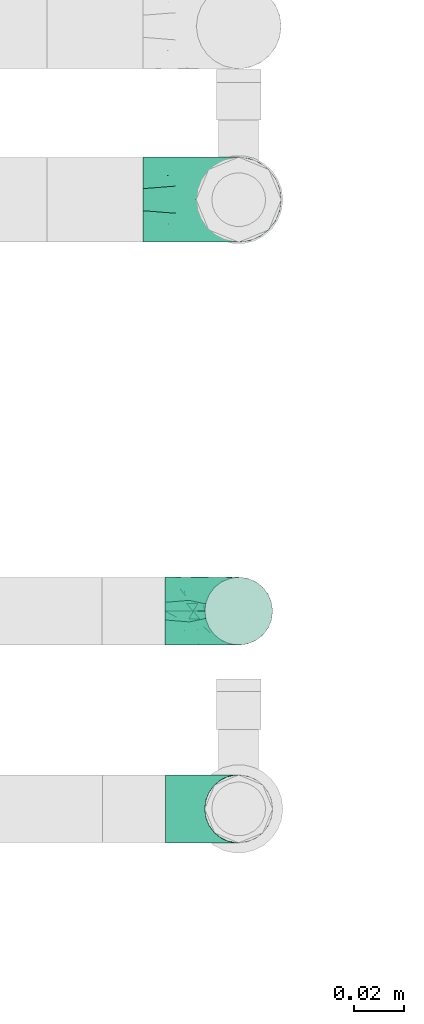
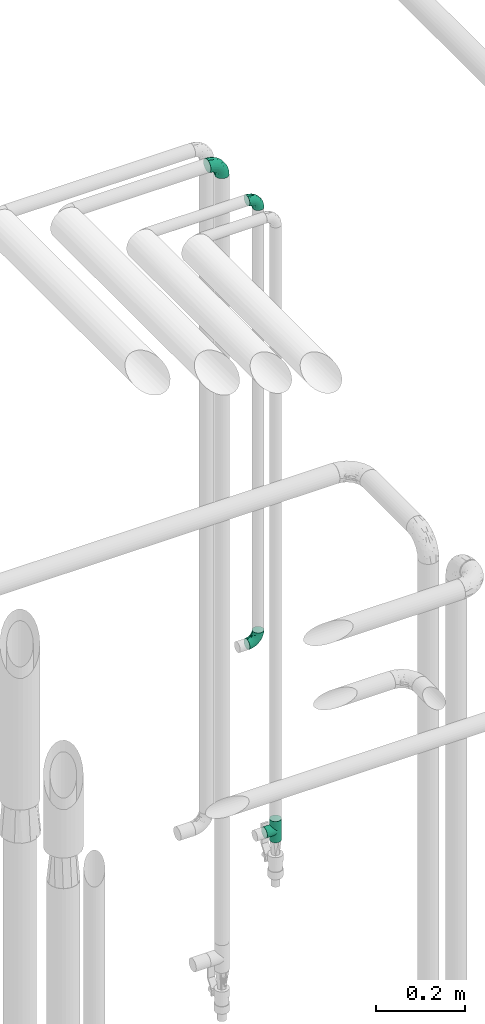
# One storey, part 747 of 827: 4 flow fittings.
"""IFC2X3 building model written with IfcOpenShell, lengths in millimetres."""

from ifc_helpers import new_model, entity, si_unit, converted_unit, derived_unit, direction, frame, origin, place, context, subcontext, project, spatial, faceted_brep, source, transform, mapped, material, type_object, type_shapes, element, save


model = new_model("IFC2X3")

# Units and contexts
model_context = context("Model", 3, precision=0.01, world=origin(), true_north=direction((6.12303176911189e-17, 1.0)))
body_context = subcontext(model_context, "Body", "Model", "MODEL_VIEW")
ifc_project = project(units=[si_unit("LENGTHUNIT", "METRE", prefix="MILLI"), si_unit("AREAUNIT", "SQUARE_METRE"), si_unit("VOLUMEUNIT", "CUBIC_METRE"), converted_unit("PLANEANGLEUNIT", "DEGREE", entity("IfcRatioMeasure", 0.0174532925199433), si_unit("PLANEANGLEUNIT", "RADIAN"), dimensions=[0, 0, 0, 0, 0, 0, 0]), si_unit("MASSUNIT", "GRAM", prefix="KILO"), derived_unit("MASSDENSITYUNIT", [(si_unit("MASSUNIT", "GRAM", prefix="KILO"), 1), (si_unit("LENGTHUNIT", "METRE"), -3)]), derived_unit("MOMENTOFINERTIAUNIT", [(si_unit("LENGTHUNIT", "METRE"), 4)]), si_unit("TIMEUNIT", "SECOND"), si_unit("FREQUENCYUNIT", "HERTZ"), si_unit("THERMODYNAMICTEMPERATUREUNIT", "DEGREE_CELSIUS"), derived_unit("THERMALTRANSMITTANCEUNIT", [(si_unit("MASSUNIT", "GRAM", prefix="KILO"), 1), (si_unit("THERMODYNAMICTEMPERATUREUNIT", "KELVIN"), -1), (si_unit("TIMEUNIT", "SECOND"), -3)]), derived_unit("VOLUMETRICFLOWRATEUNIT", [(si_unit("LENGTHUNIT", "METRE"), 3), (si_unit("TIMEUNIT", "SECOND"), -1)]), derived_unit("MASSFLOWRATEUNIT", [(si_unit("MASSUNIT", "GRAM", prefix="KILO"), 1), (si_unit("TIMEUNIT", "SECOND"), -1)]), derived_unit("ROTATIONALFREQUENCYUNIT", [(si_unit("TIMEUNIT", "SECOND"), -1)]), si_unit("ELECTRICCURRENTUNIT", "AMPERE"), si_unit("ELECTRICVOLTAGEUNIT", "VOLT"), si_unit("POWERUNIT", "WATT"), si_unit("FORCEUNIT", "NEWTON", prefix="KILO"), si_unit("ILLUMINANCEUNIT", "LUX"), si_unit("LUMINOUSFLUXUNIT", "LUMEN"), si_unit("LUMINOUSINTENSITYUNIT", "CANDELA"), derived_unit("USERDEFINED", [(si_unit("MASSUNIT", "GRAM", prefix="KILO"), -1), (si_unit("LENGTHUNIT", "METRE"), -2), (si_unit("TIMEUNIT", "SECOND"), 3), (si_unit("LUMINOUSFLUXUNIT", "LUMEN"), 1)]), derived_unit("LINEARVELOCITYUNIT", [(si_unit("LENGTHUNIT", "METRE"), 1), (si_unit("TIMEUNIT", "SECOND"), -1)]), si_unit("PRESSUREUNIT", "PASCAL"), derived_unit("USERDEFINED", [(si_unit("LENGTHUNIT", "METRE"), -2), (si_unit("MASSUNIT", "GRAM", prefix="KILO"), 1), (si_unit("TIMEUNIT", "SECOND"), -2)]), derived_unit("LINEARFORCEUNIT", [(si_unit("MASSUNIT", "GRAM", prefix="KILO"), 1), (si_unit("LENGTHUNIT", "METRE"), 1), (si_unit("TIMEUNIT", "SECOND"), -2), (si_unit("LENGTHUNIT", "METRE"), -1)]), derived_unit("PLANARFORCEUNIT", [(si_unit("MASSUNIT", "GRAM", prefix="KILO"), 1), (si_unit("LENGTHUNIT", "METRE"), 1), (si_unit("TIMEUNIT", "SECOND"), -2), (si_unit("LENGTHUNIT", "METRE"), -2)])], contexts=[model_context])

# Site, building, storey
site_placement = place(None, origin())
site = spatial("IfcSite", under=ifc_project, at=site_placement, CompositionType="ELEMENT")
building_placement = place(site_placement, origin())
building = spatial("IfcBuilding", under=site, at=building_placement, CompositionType="ELEMENT")
storey_placement = place(building_placement, frame((0.0, 0.0, 28200.0)))
storey = spatial("IfcBuildingStorey", under=building, at=storey_placement, Name="08", CompositionType="ELEMENT", Elevation=28200.0)

# Flow fittings
ifc_material = material()
pipe_fitting_type_1 = type_object("IfcPipeFittingType", Name="ADSK_1", PredefinedType="NOTDEFINED", material=ifc_material)
shared_shape_1 = source(origin(), body_context, "Body", "Brep", [
    faceted_brep([(-38.0, 0.0, -16.85), (-38.0, -4.36, -16.28), (-38.0, -8.43, -14.59), (-38.0, -11.91, -11.91), (-38.0, -14.59, -8.43), (-38.0, -16.28, -4.36), (-38.0, -16.85, 0.0), (-38.0, -16.28, 4.36), (-38.0, -14.59, 8.42), (-38.0, -11.91, 11.91), (-38.0, -8.43, 14.59), (-38.0, -4.36, 16.28), (-38.0, 0.0, 16.85), (-38.0, 4.36, 16.28), (-38.0, 8.42, 14.59), (-38.0, 11.91, 11.91), (-38.0, 14.59, 8.42), (-38.0, 16.28, 4.36), (-38.0, 16.85, 0.0), (-38.0, 16.28, -4.36), (-38.0, 14.59, -8.43), (-38.0, 11.91, -11.91), (-38.0, 8.42, -14.59), (-38.0, 4.36, -16.28), (-4.36, 38.0, -16.28), (-8.42, 38.0, -14.59), (-11.91, 38.0, -11.91), (-14.59, 38.0, -8.43), (-16.28, 38.0, -4.36), (-16.85, 38.0, 0.0), (-16.28, 38.0, 4.36), (-14.59, 38.0, 8.42), (-11.91, 38.0, 11.91), (-8.42, 38.0, 14.59), (-4.36, 38.0, 16.28), (0.0, 38.0, 16.85), (4.36, 38.0, 16.28), (8.43, 38.0, 14.59), (11.91, 38.0, 11.91), (14.59, 38.0, 8.42), (16.28, 38.0, 4.36), (16.85, 38.0, 0.0), (16.28, 38.0, -4.36), (14.59, 38.0, -8.43), (11.91, 38.0, -11.91), (8.43, 38.0, -14.59), (4.36, 38.0, -16.28), (0.0, 38.0, -16.85), (-27.9, -12.9, 9.54), (-27.5, -14.76, 0.0), (-16.53, -9.86, 8.66), (-24.93, -9.38, 12.63), (-29.29, -2.05, 16.58), (-26.82, 2.86, 16.81), (-25.18, -14.43, 5.37), (-4.54, 4.54, 14.04), (-15.36, -3.29, 14.19), (-7.56, -2.74, 10.9), (-28.06, -6.15, 15.21), (9.38, 24.93, 12.63), (-4.71, -4.42, 5.51), (-14.62, -10.99, 4.34), (-8.11, -6.73, 0.0), (-19.46, 0.42, 16.39), (-29.52, 14.25, 10.97), (-26.45, 18.14, 7.62), (-32.84, 15.94, 6.96), (-23.39, 16.22, 12.05), (-11.89, 8.53, 16.79), (-5.59, 13.42, 16.64), (-6.64, 18.62, 16.81), (-32.37, 10.35, 13.72), (-6.4, 32.67, 15.76), (-2.55, 28.48, 16.8), (6.81, 15.56, 11.71), (3.29, 15.36, 14.19), (-29.89, 18.0, 3.79), (-29.34, 6.81, 15.88), (-10.26, 4.27, 15.87), (-2.97, 11.0, 15.66), (2.45, 6.84, 10.65), (-1.8, -0.14, 8.44), (5.0, 5.5, 5.57), (-17.68, 27.4, 7.52), (14.43, 25.18, 5.37), (12.9, 27.9, 9.54), (9.86, 16.53, 8.66), (6.15, 28.06, 15.21), (-17.01, -12.67, 0.0), (2.05, 29.29, 16.58), (14.76, 27.5, 0.0), (10.99, 14.62, 4.34), (12.67, 17.01, 0.0), (-15.84, -6.82, 11.83), (-7.71, 25.61, 16.01), (-22.69, 22.69, 4.1), (-19.68, 27.42, 0.0), (-27.42, 19.68, 0.0), (-18.11, 29.67, 3.72), (-10.87, 29.33, 13.9), (-20.83, 21.64, 8.95), (-18.54, 20.86, 11.76), (-14.08, 30.19, 10.92), (-13.69, 20.27, 14.88), (-20.85, 7.92, 16.51), (-19.04, 4.79, 16.85), (-19.82, 12.26, 15.55), (-19.27, 16.43, 13.96), (-10.72, 19.56, 16.07), (-0.42, 19.46, 16.39), (-25.32, 12.08, 14.15), (-9.04, -6.0, 8.28), (-13.94, 13.94, 16.38), (0.78, -0.78, 0.0), (6.73, 8.11, 0.0), (-9.04, -6.0, -8.28), (-15.9, -7.04, -11.65), (-7.56, -2.74, -10.9), (6.15, 28.06, -15.21), (3.29, 15.36, -14.19), (-0.42, 19.46, -16.39), (-30.19, 14.08, -10.92), (-29.33, 10.87, -13.9), (-25.61, 7.71, -16.01), (-32.67, 6.4, -15.76), (-29.67, 18.11, -3.72), (-18.14, 26.45, -7.62), (-22.69, 22.69, -4.1), (-18.0, 29.89, -3.79), (-25.18, -14.43, -5.37), (-14.62, -10.99, -4.34), (-20.27, 13.69, -14.88), (-15.36, -3.29, -14.19), (-14.25, 29.52, -10.97), (-15.94, 32.84, -6.96), (-24.93, -9.38, -12.63), (-27.9, -12.9, -9.54), (6.81, 15.56, -11.71), (9.38, 24.93, -12.63), (-7.92, 20.85, -16.51), (-4.79, 19.04, -16.85), (-8.53, 11.89, -16.79), (-29.29, -2.05, -16.58), (-13.42, 5.59, -16.64), (-4.27, 10.26, -15.87), (-11.0, 2.97, -15.66), (-16.53, -9.86, -8.66), (-28.48, 2.55, -16.8), (-18.62, 6.64, -16.81), (10.99, 14.62, -4.34), (14.43, 25.18, -5.37), (-12.26, 19.82, -15.55), (-16.43, 19.27, -13.96), (12.9, 27.9, -9.54), (-10.35, 32.37, -13.72), (-6.81, 29.34, -15.88), (2.05, 29.29, -16.58), (-2.86, 26.82, -16.81), (-27.4, 17.68, -7.52), (5.0, 5.5, -5.57), (-16.22, 23.39, -12.05), (-28.06, -6.15, -15.21), (9.86, 16.53, -8.66), (-20.86, 18.54, -11.76), (-21.64, 20.83, -8.95), (-19.56, 10.72, -16.07), (-19.46, 0.42, -16.39), (-12.08, 25.32, -14.15), (-4.54, 4.54, -14.04), (-13.94, 13.94, -16.38), (2.45, 6.84, -10.65), (-4.71, -4.42, -5.51), (-1.8, -0.14, -8.44)], [[[0, 1, 2, 3, 4, 5, 6, 7, 8, 9, 10, 11, 12, 13, 14, 15, 16, 17, 18, 19, 20, 21, 22, 23]], [[24, 25, 26, 27, 28, 29, 30, 31, 32, 33, 34, 35, 36, 37, 38, 39, 40, 41, 42, 43, 44, 45, 46, 47]], [[8, 48, 9]], [[7, 6, 49]], [[48, 50, 51]], [[12, 52, 53]], [[8, 54, 48]], [[7, 54, 8]], [[55, 56, 57]], [[51, 10, 9]], [[51, 58, 10]], [[59, 38, 37]], [[60, 61, 62]], [[58, 56, 63]], [[64, 65, 66]], [[67, 65, 64]], [[68, 69, 70]], [[14, 71, 15]], [[11, 52, 12]], [[34, 72, 73]], [[12, 53, 13]], [[15, 64, 16]], [[74, 59, 75]], [[18, 17, 76]], [[66, 17, 16]], [[77, 13, 53]], [[13, 77, 14]], [[69, 78, 79]], [[80, 81, 82]], [[31, 30, 83]], [[84, 85, 86]], [[59, 87, 75]], [[61, 54, 88]], [[35, 89, 36]], [[84, 40, 39]], [[35, 34, 73]], [[90, 40, 84]], [[39, 38, 85]], [[10, 58, 11]], [[85, 84, 39]], [[91, 84, 86]], [[84, 92, 90]], [[87, 37, 36]], [[93, 56, 51]], [[94, 70, 73]], [[95, 96, 97]], [[84, 91, 92]], [[96, 98, 29]], [[33, 32, 99]], [[76, 95, 97]], [[100, 101, 83]], [[102, 99, 32]], [[65, 95, 76]], [[103, 94, 99]], [[95, 98, 96]], [[72, 99, 94]], [[72, 34, 33]], [[101, 99, 102]], [[7, 49, 54]], [[87, 59, 37]], [[104, 105, 68]], [[106, 103, 107]], [[106, 77, 104]], [[32, 31, 102]], [[94, 103, 108]], [[94, 108, 70]], [[89, 73, 109]], [[71, 64, 15]], [[110, 107, 67]], [[50, 48, 54]], [[51, 9, 48]], [[56, 58, 51]], [[88, 54, 49]], [[52, 58, 63]], [[50, 111, 93]], [[56, 55, 78]], [[38, 59, 85]], [[86, 85, 59]], [[89, 87, 36]], [[41, 40, 90]], [[109, 79, 75]], [[109, 75, 87]], [[75, 55, 80]], [[104, 77, 53]], [[71, 77, 110]], [[31, 83, 102]], [[101, 102, 83]], [[99, 101, 103]], [[106, 107, 110]], [[68, 70, 112]], [[109, 73, 70]], [[68, 112, 104]], [[68, 63, 78]], [[57, 93, 111]], [[80, 55, 57]], [[61, 50, 54]], [[80, 82, 86]], [[81, 57, 111]], [[74, 86, 59]], [[60, 113, 82]], [[82, 114, 91]], [[100, 95, 65]], [[98, 95, 83]], [[73, 89, 35]], [[87, 89, 109]], [[58, 52, 11]], [[53, 52, 63]], [[104, 53, 105]], [[106, 104, 112]], [[18, 76, 97]], [[76, 17, 66]], [[103, 106, 112]], [[77, 106, 110]], [[103, 101, 107]], [[67, 107, 101]], [[67, 101, 100]], [[110, 67, 64]], [[83, 30, 98]], [[29, 98, 30]], [[53, 63, 105]], [[63, 68, 105]], [[56, 78, 63]], [[79, 78, 55]], [[75, 79, 55]], [[69, 79, 109]], [[70, 69, 109]], [[78, 69, 68]], [[62, 113, 60]], [[111, 61, 60]], [[61, 88, 62]], [[86, 82, 91]], [[77, 71, 14]], [[114, 82, 113]], [[114, 92, 91]], [[64, 71, 110]], [[99, 72, 33]], [[73, 72, 94]], [[64, 66, 16]], [[76, 66, 65]], [[95, 100, 83]], [[67, 100, 65]], [[75, 80, 74]], [[80, 86, 74]], [[103, 112, 108]], [[70, 108, 112]], [[50, 93, 51]], [[57, 56, 93]], [[61, 111, 50]], [[81, 111, 60]], [[82, 81, 60]], [[80, 57, 81]], [[115, 116, 117]], [[118, 119, 120]], [[121, 122, 21]], [[123, 124, 122]], [[97, 125, 18]], [[126, 127, 128]], [[127, 97, 96]], [[129, 130, 88]], [[123, 122, 131]], [[116, 132, 117]], [[133, 126, 134]], [[22, 124, 23]], [[3, 135, 136]], [[137, 119, 138]], [[129, 88, 49]], [[139, 140, 141]], [[4, 3, 136]], [[45, 118, 46]], [[142, 1, 0]], [[143, 144, 145]], [[4, 129, 5]], [[129, 136, 146]], [[147, 0, 23]], [[22, 21, 122]], [[127, 125, 97]], [[123, 148, 147]], [[96, 128, 127]], [[149, 150, 92]], [[29, 28, 128]], [[151, 131, 152]], [[26, 133, 27]], [[153, 44, 43]], [[135, 3, 2]], [[26, 25, 154]], [[155, 25, 24]], [[47, 156, 157]], [[47, 46, 156]], [[20, 19, 158]], [[159, 149, 114]], [[126, 133, 160]], [[141, 143, 148]], [[45, 138, 118]], [[161, 135, 2]], [[155, 24, 157]], [[23, 124, 147]], [[115, 146, 116]], [[44, 153, 138]], [[138, 45, 44]], [[153, 162, 138]], [[161, 2, 1]], [[41, 90, 42]], [[130, 129, 146]], [[49, 5, 129]], [[42, 150, 43]], [[163, 122, 121]], [[47, 157, 24]], [[135, 161, 132]], [[134, 28, 27]], [[42, 90, 150]], [[164, 163, 158]], [[151, 155, 139]], [[21, 20, 121]], [[123, 131, 165]], [[123, 165, 148]], [[142, 147, 166]], [[154, 133, 26]], [[167, 152, 160]], [[146, 136, 135]], [[6, 5, 49]], [[129, 4, 136]], [[142, 161, 1]], [[166, 145, 132]], [[166, 132, 161]], [[132, 168, 117]], [[43, 150, 153]], [[92, 150, 90]], [[162, 153, 150]], [[119, 118, 138]], [[156, 118, 120]], [[137, 138, 162]], [[119, 168, 144]], [[139, 155, 157]], [[154, 155, 167]], [[20, 158, 121]], [[163, 121, 158]], [[122, 163, 131]], [[151, 152, 167]], [[141, 148, 169]], [[166, 147, 148]], [[141, 169, 139]], [[141, 120, 144]], [[168, 170, 117]], [[159, 171, 172]], [[115, 172, 171]], [[171, 62, 130]], [[119, 170, 168]], [[170, 162, 159]], [[149, 162, 150]], [[113, 171, 159]], [[164, 127, 126]], [[125, 127, 158]], [[147, 142, 0]], [[161, 142, 166]], [[118, 156, 46]], [[157, 156, 120]], [[139, 157, 140]], [[151, 139, 169]], [[29, 128, 96]], [[128, 28, 134]], [[131, 151, 169]], [[155, 151, 167]], [[131, 163, 152]], [[160, 152, 163]], [[160, 163, 164]], [[167, 160, 133]], [[158, 19, 125]], [[18, 125, 19]], [[157, 120, 140]], [[120, 141, 140]], [[119, 144, 120]], [[145, 144, 168]], [[132, 145, 168]], [[143, 145, 166]], [[148, 143, 166]], [[144, 143, 141]], [[115, 130, 146]], [[114, 113, 159]], [[62, 171, 113]], [[62, 88, 130]], [[159, 162, 149]], [[149, 92, 114]], [[155, 154, 25]], [[133, 154, 167]], [[122, 124, 22]], [[147, 124, 123]], [[133, 134, 27]], [[128, 134, 126]], [[127, 164, 158]], [[160, 164, 126]], [[162, 170, 137]], [[170, 119, 137]], [[131, 169, 165]], [[148, 165, 169]], [[146, 135, 116]], [[132, 116, 135]], [[172, 115, 117]], [[130, 115, 171]], [[117, 170, 172]], [[159, 172, 170]]]),
])
type_shapes(pipe_fitting_type_1, [shared_shape_1])
flow_fitting_1_placement = place(storey_placement, frame((18905.55, 16517.91, 2600.0), z_axis=(0.0, 1.0, 0.0), x_axis=(1.0, 0.0, 0.0)))
element("IfcFlowFitting", 1, at=flow_fitting_1_placement, inside=storey, type_object=pipe_fitting_type_1, material=ifc_material, Name="ADSK_1", ObjectType="ADSK_1", context=body_context, shape_type="MappedRepresentation", body=[
    mapped(shared_shape_1, transform((0.0, 0.0, 0.0), scale=1.0)),
])
pipe_fitting_type_2 = type_object("IfcPipeFittingType", Name="ADSK_1", PredefinedType="NOTDEFINED", material=ifc_material)
shared_shape_2 = source(origin(), body_context, "Body", "Brep", [
    faceted_brep([(-29.1, 0.0, -13.45), (-29.1, -3.48, -12.99), (-29.1, -6.73, -11.65), (-29.1, -9.51, -9.51), (-29.1, -11.65, -6.73), (-29.1, -12.99, -3.48), (-29.1, -13.45, 0.0), (-29.1, -12.99, 3.48), (-29.1, -11.65, 6.72), (-29.1, -9.51, 9.51), (-29.1, -6.73, 11.65), (-29.1, -3.48, 12.99), (-29.1, 0.0, 13.45), (-29.1, 3.48, 12.99), (-29.1, 6.72, 11.65), (-29.1, 9.51, 9.51), (-29.1, 11.65, 6.72), (-29.1, 12.99, 3.48), (-29.1, 13.45, 0.0), (-29.1, 12.99, -3.48), (-29.1, 11.65, -6.73), (-29.1, 9.51, -9.51), (-29.1, 6.72, -11.65), (-29.1, 3.48, -12.99), (-3.48, 29.1, -12.99), (-6.72, 29.1, -11.65), (-9.51, 29.1, -9.51), (-11.65, 29.1, -6.73), (-12.99, 29.1, -3.48), (-13.45, 29.1, 0.0), (-12.99, 29.1, 3.48), (-11.65, 29.1, 6.72), (-9.51, 29.1, 9.51), (-6.72, 29.1, 11.65), (-3.48, 29.1, 12.99), (0.0, 29.1, 13.45), (3.48, 29.1, 12.99), (6.73, 29.1, 11.65), (9.51, 29.1, 9.51), (11.65, 29.1, 6.72), (12.99, 29.1, 3.48), (13.45, 29.1, 0.0), (12.99, 29.1, -3.48), (11.65, 29.1, -6.73), (9.51, 29.1, -9.51), (6.73, 29.1, -11.65), (3.48, 29.1, -12.99), (0.0, 29.1, -13.45), (-19.62, -11.66, 4.28), (-21.41, -10.36, 7.6), (-16.26, -10.01, 0.0), (-12.48, -9.76, 2.75), (-10.66, 15.6, 11.91), (-15.27, 9.55, 12.42), (-10.71, 10.71, 13.09), (-0.04, 0.04, 0.0), (0.49, -0.45, 4.38), (-3.67, -4.15, 4.26), (-22.68, -11.73, 0.0), (-21.45, -4.97, 12.13), (-11.59, -2.84, 11.28), (-14.77, 0.17, 13.07), (-19.08, -7.58, 10.06), (-22.36, -1.69, 13.23), (-20.49, 2.21, 13.42), (-7.82, -7.75, 0.0), (-5.53, -2.55, 8.58), (-1.33, -0.87, 6.53), (-1.15, 1.15, 8.49), (-22.46, 5.38, 12.69), (-14.04, 21.05, 6.04), (-3.19, 3.19, 11.14), (-5.08, 25.05, 12.59), (-1.97, 21.79, 13.41), (-22.68, 11.31, 8.78), (-18.16, 12.64, 9.68), (-20.46, 14.33, 6.11), (-4.13, 10.11, 13.26), (-7.66, 3.08, 12.63), (-2.02, 8.24, 12.45), (-24.91, 8.22, 10.95), (-5.08, 14.28, 13.42), (-8.96, 6.48, 13.4), (-19.7, 16.14, 3.1), (-18.03, 18.03, 0.0), (-23.05, 15.96, 0.0), (-25.26, 12.69, 5.56), (4.97, 21.45, 12.13), (7.58, 19.08, 10.06), (1.69, 22.36, 13.23), (10.36, 21.41, 7.6), (8.11, 12.69, 6.86), (11.66, 19.62, 4.28), (-6.03, 19.65, 12.79), (9.76, 12.48, 2.75), (10.01, 16.26, 0.0), (-14.58, 16.06, 9.44), (-11.19, 23.14, 8.74), (-16.29, 16.8, 7.24), (-11.99, -5.68, 9.36), (-15.42, 20.78, 3.08), (5.79, 12.02, 9.27), (2.84, 11.59, 11.28), (2.55, 5.53, 8.58), (-15.74, 23.57, 0.0), (-15.96, 23.05, 0.0), (-24.62, 13.88, 2.39), (-8.61, 22.49, 11.12), (-14.98, 12.8, 11.14), (11.73, 22.68, 0.0), (-12.69, -8.11, 6.86), (7.75, 7.82, 0.0), (-15.98, 6.12, 13.19), (-14.48, 3.64, 13.45), (-19.6, 9.46, 11.31), (-8.3, 15.02, 12.85), (-0.17, 14.77, 13.07), (-6.9, -5.2, 6.52), (7.5, 8.93, 4.46), (5.22, 6.95, 6.56), (-8.85, -7.47, 4.42), (3.86, 3.93, 0.0), (4.18, 3.75, 4.31), (-23.57, 15.74, 0.0), (-3.93, -3.86, 0.0), (-21.79, 1.97, -13.41), (-11.31, 22.68, -8.78), (-14.33, 20.46, -6.11), (-12.69, 25.26, -5.56), (4.97, 21.45, -12.13), (2.84, 11.59, -11.28), (-0.17, 14.77, -13.07), (-25.05, 5.08, -12.59), (-16.8, 16.29, -7.24), (-20.78, 15.42, -3.08), (-16.14, 19.7, -3.1), (-12.02, -5.79, -9.27), (-11.59, -2.84, -11.28), (-5.53, -2.55, -8.58), (-23.14, 11.19, -8.74), (-22.49, 8.61, -11.12), (-1.33, -0.87, -6.53), (-3.67, -4.15, -4.26), (-6.9, -5.2, -6.52), (-19.65, 6.03, -12.79), (-15.6, 10.66, -11.91), (-14.28, 5.08, -13.42), (-10.71, 10.71, -13.09), (-6.48, 8.96, -13.4), (-19.62, -11.66, -4.28), (-21.41, -10.36, -7.6), (-12.48, -9.76, -2.75), (11.66, 19.62, -4.28), (-12.69, -8.11, -6.86), (-22.36, -1.69, -13.23), (-16.06, 14.58, -9.44), (5.68, 11.99, -9.36), (7.58, 19.08, -10.06), (-19.08, -7.58, -10.06), (-21.45, -4.97, -12.13), (-9.55, 15.27, -12.42), (-12.8, 14.98, -11.14), (-8.22, 24.91, -10.95), (10.36, 21.41, -7.6), (-5.38, 22.46, -12.69), (1.69, 22.36, -13.23), (-2.21, 20.49, -13.42), (-12.64, 18.16, -9.68), (-21.05, 14.04, -6.04), (9.76, 12.48, -2.75), (-10.11, 4.13, -13.26), (-3.08, 7.66, -12.63), (-8.24, 2.02, -12.45), (-13.88, 24.62, -2.39), (8.11, 12.69, -6.86), (-6.12, 15.98, -13.19), (-3.64, 14.48, -13.45), (-9.46, 19.6, -11.31), (-15.02, 8.3, -12.85), (-14.77, 0.17, -13.07), (-3.19, 3.19, -11.14), (5.22, 6.95, -6.56), (2.55, 5.53, -8.58), (0.49, -0.45, -4.38), (4.18, 3.75, -4.31), (-8.85, -7.47, -4.42), (-1.15, 1.15, -8.49), (7.5, 8.93, -4.46)], [[[0, 1, 2, 3, 4, 5, 6, 7, 8, 9, 10, 11, 12, 13, 14, 15, 16, 17, 18, 19, 20, 21, 22, 23]], [[24, 25, 26, 27, 28, 29, 30, 31, 32, 33, 34, 35, 36, 37, 38, 39, 40, 41, 42, 43, 44, 45, 46, 47]], [[48, 49, 8]], [[48, 50, 51]], [[52, 53, 54]], [[55, 56, 57]], [[49, 9, 8]], [[58, 48, 7]], [[59, 60, 61]], [[62, 10, 9]], [[62, 59, 10]], [[12, 63, 64]], [[51, 50, 65]], [[66, 67, 68]], [[12, 11, 63]], [[69, 14, 13]], [[31, 30, 70]], [[66, 71, 60]], [[34, 72, 73]], [[74, 75, 76]], [[77, 78, 79]], [[14, 80, 15]], [[16, 15, 74]], [[81, 54, 82]], [[83, 84, 85]], [[74, 76, 86]], [[37, 87, 88]], [[88, 38, 37]], [[36, 35, 89]], [[90, 91, 92]], [[93, 81, 73]], [[35, 34, 73]], [[10, 59, 11]], [[92, 94, 95]], [[96, 97, 98]], [[90, 92, 39]], [[99, 60, 62]], [[40, 39, 92]], [[87, 37, 36]], [[100, 84, 83]], [[50, 48, 58]], [[100, 83, 98]], [[101, 102, 103]], [[104, 105, 84, 100, 29]], [[48, 8, 7]], [[86, 17, 16]], [[106, 18, 17]], [[32, 97, 107]], [[53, 52, 108]], [[52, 93, 107]], [[97, 96, 107]], [[72, 107, 93]], [[72, 34, 33]], [[92, 109, 40]], [[33, 32, 107]], [[69, 13, 64]], [[88, 87, 102]], [[12, 64, 13]], [[49, 110, 62]], [[39, 38, 90]], [[95, 94, 111]], [[112, 113, 82]], [[53, 69, 112]], [[80, 74, 15]], [[114, 108, 75]], [[32, 31, 97]], [[115, 52, 54]], [[93, 115, 81]], [[89, 73, 116]], [[106, 76, 83]], [[106, 83, 85]], [[83, 76, 98]], [[100, 30, 29]], [[60, 59, 62]], [[63, 59, 61]], [[110, 117, 99]], [[60, 71, 78]], [[89, 87, 36]], [[116, 79, 102]], [[116, 102, 87]], [[102, 71, 103]], [[110, 49, 48]], [[62, 9, 49]], [[38, 88, 90]], [[91, 90, 88]], [[112, 69, 64]], [[80, 69, 114]], [[111, 94, 118]], [[119, 101, 103]], [[117, 66, 99]], [[117, 120, 57]], [[119, 91, 101]], [[66, 68, 71]], [[66, 117, 67]], [[121, 111, 122, 55]], [[56, 55, 122]], [[31, 70, 97]], [[97, 70, 98]], [[107, 96, 52]], [[53, 108, 114]], [[112, 82, 54]], [[116, 73, 81]], [[78, 82, 61]], [[81, 82, 77]], [[73, 89, 35]], [[87, 89, 116]], [[59, 63, 11]], [[64, 63, 61]], [[112, 64, 113]], [[53, 112, 54]], [[7, 6, 58]], [[109, 92, 95]], [[109, 41, 40]], [[69, 53, 114]], [[52, 96, 108]], [[75, 108, 96]], [[75, 96, 98]], [[114, 75, 74]], [[64, 61, 113]], [[61, 82, 113]], [[91, 88, 101]], [[110, 48, 51]], [[92, 91, 94]], [[91, 119, 118]], [[106, 85, 123, 18]], [[106, 17, 86]], [[60, 78, 61]], [[79, 78, 71]], [[102, 79, 71]], [[77, 79, 116]], [[81, 77, 116]], [[78, 77, 82]], [[69, 80, 14]], [[74, 80, 114]], [[74, 86, 16]], [[106, 86, 76]], [[107, 72, 33]], [[73, 72, 93]], [[98, 70, 100]], [[75, 98, 76]], [[30, 100, 70]], [[110, 99, 62]], [[66, 60, 99]], [[120, 110, 51]], [[67, 117, 57]], [[57, 56, 67]], [[67, 122, 119]], [[110, 120, 117]], [[65, 120, 51]], [[57, 65, 124, 55]], [[122, 67, 56]], [[67, 103, 68]], [[71, 68, 103]], [[65, 57, 120]], [[102, 101, 88]], [[67, 119, 103]], [[118, 119, 122]], [[118, 122, 111]], [[91, 118, 94]], [[81, 115, 54]], [[93, 52, 115]], [[23, 125, 0]], [[126, 127, 128]], [[129, 130, 131]], [[23, 22, 132]], [[133, 134, 135]], [[136, 137, 138]], [[21, 139, 140]], [[141, 142, 143]], [[144, 140, 145]], [[143, 136, 138]], [[146, 147, 148]], [[144, 132, 140]], [[5, 4, 149]], [[4, 3, 150]], [[45, 129, 46]], [[151, 50, 149]], [[152, 43, 42]], [[42, 41, 109]], [[150, 149, 4]], [[153, 149, 150]], [[154, 1, 0]], [[139, 155, 140]], [[156, 130, 157]], [[149, 58, 5]], [[18, 123, 85, 84, 134]], [[158, 159, 137]], [[84, 105, 135]], [[160, 145, 161]], [[143, 153, 136]], [[27, 26, 126]], [[25, 162, 26]], [[152, 163, 43]], [[25, 24, 164]], [[47, 165, 166]], [[158, 3, 2]], [[167, 127, 126]], [[20, 19, 168]], [[47, 46, 165]], [[44, 157, 45]], [[23, 132, 125]], [[44, 43, 163]], [[158, 2, 159]], [[47, 166, 24]], [[129, 45, 157]], [[164, 24, 166]], [[134, 84, 135]], [[95, 169, 152]], [[22, 21, 140]], [[144, 146, 125]], [[109, 152, 42]], [[95, 152, 109]], [[170, 171, 172]], [[155, 139, 133]], [[28, 27, 128]], [[159, 2, 1]], [[173, 29, 28]], [[50, 151, 65]], [[169, 95, 111]], [[163, 174, 157]], [[175, 176, 148]], [[160, 164, 175]], [[162, 126, 26]], [[177, 161, 167]], [[21, 20, 139]], [[144, 145, 178]], [[144, 178, 146]], [[154, 125, 179]], [[173, 127, 135]], [[173, 135, 105]], [[135, 127, 133]], [[134, 19, 18]], [[154, 159, 1]], [[179, 172, 137]], [[179, 137, 159]], [[137, 180, 138]], [[130, 129, 157]], [[165, 129, 131]], [[174, 181, 156]], [[130, 180, 171]], [[3, 158, 150]], [[153, 150, 158]], [[174, 163, 152]], [[157, 44, 163]], [[175, 164, 166]], [[162, 164, 177]], [[130, 182, 180]], [[181, 141, 182]], [[55, 183, 184]], [[65, 151, 185]], [[183, 55, 142]], [[156, 181, 182]], [[180, 182, 186]], [[181, 187, 184]], [[65, 142, 55, 124]], [[20, 168, 139]], [[139, 168, 133]], [[140, 155, 145]], [[160, 161, 177]], [[175, 148, 147]], [[179, 125, 146]], [[171, 148, 131]], [[146, 148, 170]], [[125, 154, 0]], [[159, 154, 179]], [[129, 165, 46]], [[166, 165, 131]], [[175, 166, 176]], [[160, 175, 147]], [[58, 149, 50]], [[58, 6, 5]], [[145, 160, 147]], [[164, 160, 177]], [[145, 155, 161]], [[167, 161, 155]], [[167, 155, 133]], [[177, 167, 126]], [[166, 131, 176]], [[131, 148, 176]], [[149, 153, 151]], [[153, 143, 185]], [[145, 147, 178]], [[174, 152, 169]], [[173, 105, 104, 29]], [[173, 28, 128]], [[130, 171, 131]], [[172, 171, 180]], [[137, 172, 180]], [[170, 172, 179]], [[146, 170, 179]], [[171, 170, 148]], [[164, 162, 25]], [[126, 162, 177]], [[126, 128, 27]], [[173, 128, 127]], [[140, 132, 22]], [[125, 132, 144]], [[133, 168, 134]], [[167, 133, 127]], [[19, 134, 168]], [[153, 158, 136]], [[137, 136, 158]], [[141, 143, 138]], [[185, 143, 142]], [[186, 141, 138]], [[183, 142, 141]], [[185, 142, 65]], [[153, 185, 151]], [[180, 186, 138]], [[182, 141, 186]], [[141, 184, 183]], [[184, 111, 121, 55]], [[174, 156, 157]], [[182, 130, 156]], [[187, 174, 169]], [[141, 181, 184]], [[174, 187, 181]], [[111, 187, 169]], [[111, 184, 187]], [[146, 178, 147]]]),
])
type_shapes(pipe_fitting_type_2, [shared_shape_2])
for number, where, z_axis, x_axis, name in (
    (2, (18905.55, 16354.91, 2600.0), (0.0, 1.0, 0.0), (1.0, 0.0, 0.0), "ADSK_1"),
    (3, (18905.55, 16354.91, 1382.4), (0.0, 1.0, 0.0), (0.0, 0.0, -1.0), "ADSK_1"),
):
    element("IfcFlowFitting", number, at=place(storey_placement, frame(where, z_axis=z_axis, x_axis=x_axis)), inside=storey, type_object=pipe_fitting_type_2, material=ifc_material, Name=name, ObjectType="ADSK_1", context=body_context, shape_type="MappedRepresentation", body=[
        mapped(shared_shape_2, transform((0.0, 0.0, 0.0), scale=1.0)),
    ])
pipe_fitting_type_3 = type_object("IfcPipeFittingType", Name="ADSK_1", PredefinedType="NOTDEFINED", material=ifc_material)
shared_shape_3 = source(origin(), body_context, "Body", "Brep", [
    faceted_brep([(-29.0, 3.48, -12.99), (-29.0, 0.0, -13.45), (-29.0, -3.48, -12.99), (-29.0, -6.73, -11.65), (-29.0, -9.51, -9.51), (-29.0, -11.65, -6.73), (-29.0, -12.99, -3.48), (-29.0, -13.45, 0.0), (-29.0, -12.99, 3.48), (-29.0, -11.65, 6.72), (-29.0, -9.51, 9.51), (-29.0, -6.73, 11.65), (-29.0, -3.48, 12.99), (-29.0, 0.0, 13.45), (-29.0, 3.48, 12.99), (-29.0, 6.72, 11.65), (-29.0, 9.51, 9.51), (-29.0, 11.65, 6.72), (-29.0, 12.99, 3.48), (-29.0, 13.45, 0.0), (-29.0, 12.99, -3.48), (-29.0, 11.65, -6.73), (-29.0, 9.51, -9.51), (-29.0, 6.72, -11.65), (29.0, 11.65, -6.73), (29.0, 12.99, -3.48), (29.0, 13.45, 0.0), (29.0, 12.99, 3.48), (29.0, 11.65, 6.72), (29.0, 9.51, 9.51), (29.0, 6.72, 11.65), (29.0, 3.48, 12.99), (29.0, 0.0, 13.45), (29.0, -3.48, 12.99), (29.0, -6.73, 11.65), (29.0, -9.51, 9.51), (29.0, -11.65, 6.72), (29.0, -12.99, 3.48), (29.0, -13.45, 0.0), (29.0, -12.99, -3.48), (29.0, -11.65, -6.73), (29.0, -9.51, -9.51), (29.0, -6.73, -11.65), (29.0, -3.48, -12.99), (29.0, 0.0, -13.45), (29.0, 3.48, -12.99), (29.0, 6.72, -11.65), (29.0, 9.51, -9.51), (12.96, -12.96, 3.59), (13.45, -13.45, 0.0), (-13.45, -13.45, 0.0), (11.64, -11.64, 6.74), (7.54, -7.54, 11.14), (9.76, -9.76, 9.25), (-12.96, -12.96, 3.59), (-11.64, -11.64, 6.74), (-9.76, -9.76, 9.25), (-7.54, -7.54, 11.14), (-5.12, -5.12, 12.44), (5.12, -5.12, 12.44), (2.58, -2.58, 13.2), (0.0, 0.0, 13.45), (-2.58, -2.58, 13.2), (2.58, -2.58, -13.2), (0.0, 0.0, -13.45), (-2.58, -2.58, -13.2), (-5.12, -5.12, -12.44), (5.12, -5.12, -12.44), (7.54, -7.54, -11.14), (9.76, -9.76, -9.25), (11.64, -11.64, -6.74), (12.96, -12.96, -3.59), (-7.54, -7.54, -11.14), (-9.76, -9.76, -9.25), (-12.96, -12.96, -3.59), (-11.64, -11.64, -6.74), (-12.99, -29.0, -3.48), (-11.65, -29.0, -6.73), (-9.51, -29.0, -9.51), (-6.72, -29.0, -11.65), (-3.48, -29.0, -12.99), (0.0, -29.0, -13.45), (3.48, -29.0, -12.99), (6.73, -29.0, -11.65), (9.51, -29.0, -9.51), (11.65, -29.0, -6.73), (12.99, -29.0, -3.48), (13.45, -29.0, 0.0), (12.99, -29.0, 3.48), (11.65, -29.0, 6.72), (9.51, -29.0, 9.51), (6.73, -29.0, 11.65), (3.48, -29.0, 12.99), (0.0, -29.0, 13.45), (-3.48, -29.0, 12.99), (-6.72, -29.0, 11.65), (-9.51, -29.0, 9.51), (-11.65, -29.0, 6.72), (-12.99, -29.0, 3.48), (-13.45, -29.0, 0.0)], [[[0, 1, 2, 3, 4, 5, 6, 7, 8, 9, 10, 11, 12, 13, 14, 15, 16, 17, 18, 19, 20, 21, 22, 23]], [[24, 25, 26, 27, 28, 29, 30, 31, 32, 33, 34, 35, 36, 37, 38, 39, 40, 41, 42, 43, 44, 45, 46, 47]], [[37, 36, 48]], [[38, 37, 49]], [[50, 8, 7]], [[49, 37, 48]], [[36, 51, 48]], [[35, 34, 52]], [[51, 36, 53]], [[52, 53, 35]], [[53, 36, 35]], [[50, 54, 8]], [[8, 54, 9]], [[54, 55, 9]], [[56, 57, 10]], [[10, 9, 56]], [[10, 57, 11]], [[56, 9, 55]], [[11, 57, 58]], [[52, 34, 59]], [[60, 32, 61]], [[62, 61, 13]], [[59, 33, 60]], [[33, 59, 34]], [[60, 33, 32]], [[61, 32, 31, 14, 13]], [[28, 27, 18, 17]], [[16, 15, 30, 29]], [[17, 16, 29, 28]], [[31, 30, 15, 14]], [[19, 18, 27, 26]], [[62, 12, 58]], [[12, 62, 13]], [[58, 12, 11]], [[47, 22, 21, 24]], [[25, 20, 19, 26]], [[25, 24, 21, 20]], [[23, 22, 47, 46]], [[44, 43, 63]], [[44, 64, 1, 0, 45]], [[64, 44, 63]], [[1, 64, 65]], [[46, 45, 0, 23]], [[65, 66, 2]], [[1, 65, 2]], [[66, 3, 2]], [[63, 43, 67]], [[42, 41, 68]], [[69, 68, 41]], [[40, 70, 69]], [[69, 41, 40]], [[42, 68, 67]], [[39, 38, 49]], [[6, 50, 7]], [[39, 71, 40]], [[71, 39, 49]], [[40, 71, 70]], [[72, 3, 66]], [[72, 4, 3]], [[4, 72, 73]], [[4, 73, 5]], [[74, 50, 6]], [[75, 74, 5]], [[74, 6, 5]], [[75, 5, 73]], [[42, 67, 43]], [[76, 77, 78, 79, 80, 81, 82, 83, 84, 85, 86, 87, 88, 89, 90, 91, 92, 93, 94, 95, 96, 97, 98, 99]], [[99, 98, 50]], [[54, 50, 98]], [[96, 95, 57]], [[97, 96, 56]], [[97, 54, 98]], [[58, 95, 94]], [[55, 54, 97]], [[56, 55, 97]], [[58, 57, 95]], [[93, 61, 62]], [[58, 94, 62]], [[56, 96, 57]], [[62, 94, 93]], [[60, 93, 92]], [[91, 59, 92]], [[89, 88, 48]], [[53, 90, 89]], [[52, 91, 90]], [[49, 88, 87]], [[59, 60, 92]], [[52, 59, 91]], [[49, 48, 88]], [[51, 53, 89]], [[48, 51, 89]], [[52, 90, 53]], [[93, 60, 61]], [[87, 86, 49]], [[71, 49, 86]], [[69, 85, 84]], [[68, 84, 83]], [[86, 85, 71]], [[67, 83, 82]], [[70, 71, 85]], [[69, 70, 85]], [[67, 68, 83]], [[81, 64, 63]], [[67, 82, 63]], [[69, 84, 68]], [[63, 82, 81]], [[65, 81, 80]], [[79, 66, 80]], [[77, 76, 74]], [[73, 78, 77]], [[72, 79, 78]], [[50, 76, 99]], [[66, 65, 80]], [[72, 66, 79]], [[50, 74, 76]], [[75, 73, 77]], [[74, 75, 77]], [[72, 78, 73]], [[81, 65, 64]]]),
])
type_shapes(pipe_fitting_type_3, [shared_shape_3])
flow_fitting_2_placement = place(storey_placement, frame((18905.55, 16276.57, 912.61), z_axis=(0.0, 1.0, 0.0), x_axis=(0.0, 0.0, 1.0)))
element("IfcFlowFitting", 4, at=flow_fitting_2_placement, inside=storey, type_object=pipe_fitting_type_3, material=ifc_material, Name="ADSK_1", ObjectType="ADSK_1", context=body_context, shape_type="MappedRepresentation", body=[
    mapped(shared_shape_3, transform((0.0, 0.0, 0.0), scale=1.0)),
])

save(model, "model.ifc")
